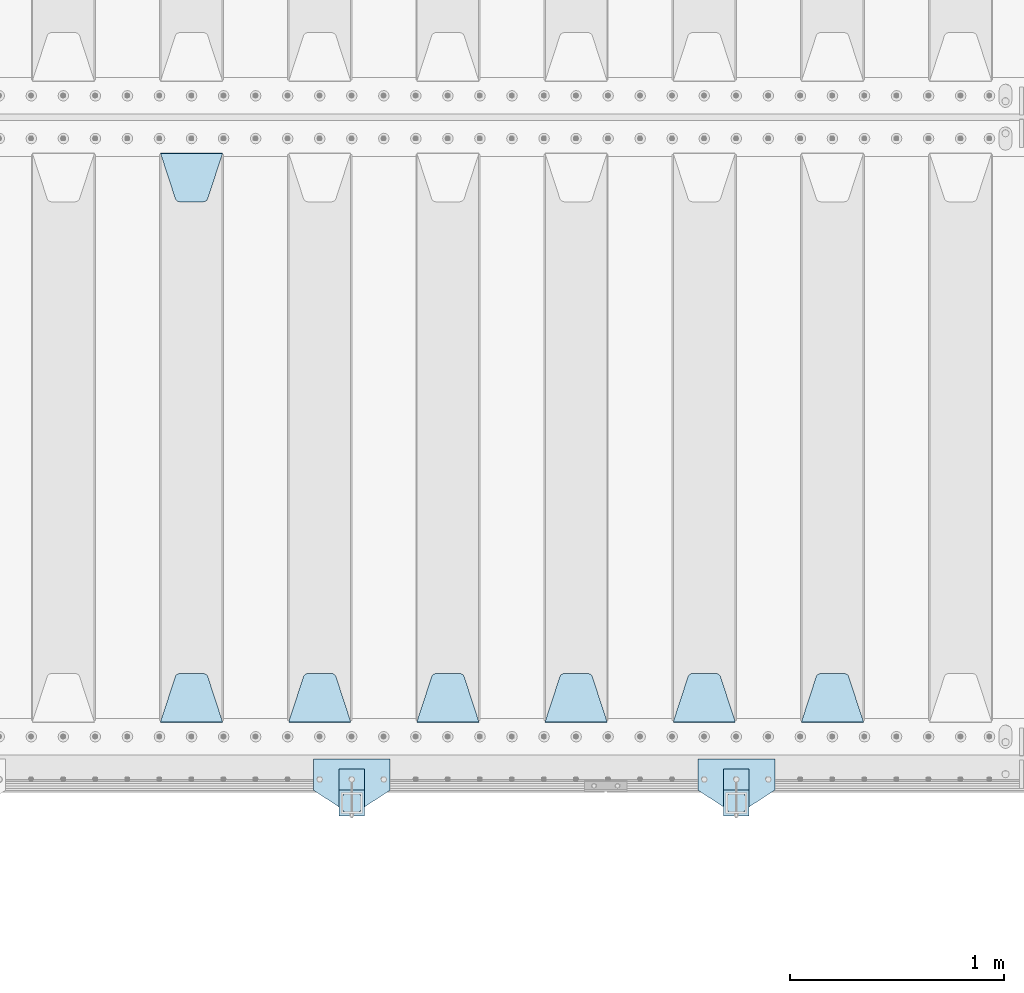
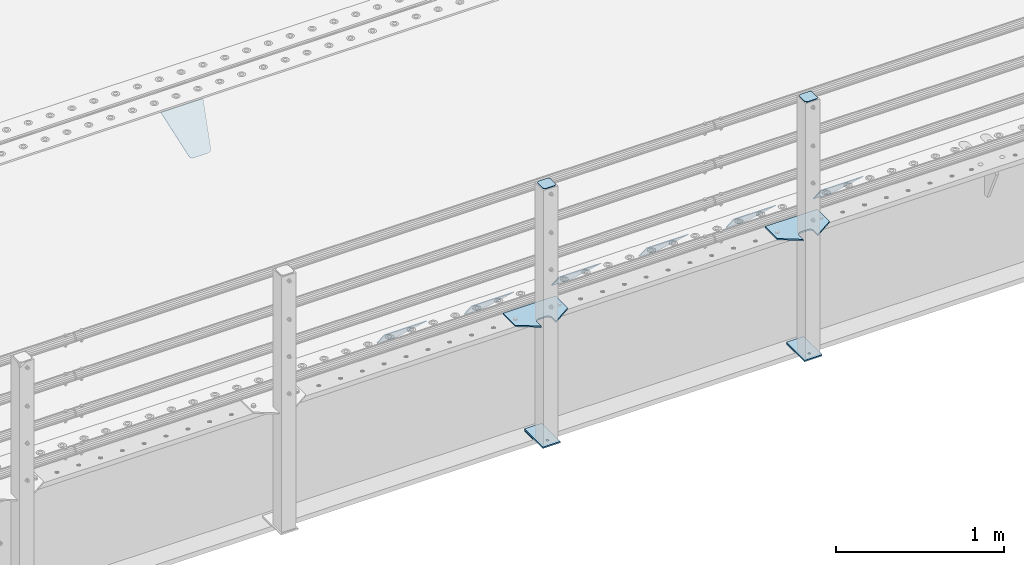
# One storey, part 216 of 270: 15 plates.
"""IFC2X3 building model written with IfcOpenShell, lengths in millimetres."""

from ifc_helpers import new_model, si_unit, frame, origin_with_axes, place, context, subcontext, project, spatial, faceted_brep, material, type_object, element, save


model = new_model("IFC2X3")

# Units and contexts
model_context = context("Model", 3, precision=1e-05, world=origin_with_axes())
body_context = subcontext(model_context, "Body", "Model", "MODEL_VIEW")
ifc_project = project(units=[si_unit("LENGTHUNIT", "METRE", prefix="MILLI"), si_unit("AREAUNIT", "SQUARE_METRE"), si_unit("VOLUMEUNIT", "CUBIC_METRE"), si_unit("MASSUNIT", "GRAM", prefix="KILO"), si_unit("TIMEUNIT", "SECOND"), si_unit("PLANEANGLEUNIT", "RADIAN"), si_unit("SOLIDANGLEUNIT", "STERADIAN"), si_unit("THERMODYNAMICTEMPERATUREUNIT", "DEGREE_CELSIUS"), si_unit("LUMINOUSINTENSITYUNIT", "LUMEN")], contexts=[model_context])

# Site, building, storey
site_placement = place(None, origin_with_axes())
site = spatial("IfcSite", under=ifc_project, at=site_placement, CompositionType="ELEMENT")
building_placement = place(site_placement, origin_with_axes())
building = spatial("IfcBuilding", under=site, at=building_placement, Name="Standard", CompositionType="ELEMENT")
storey_placement = place(building_placement, origin_with_axes())
storey = spatial("IfcBuildingStorey", under=building, at=storey_placement, Name="Undefined", CompositionType="ELEMENT", Elevation=0.0)

# Plates
ifc_material_1 = material(Name="STEEL/S355J2")
plate_type_1 = type_object("IfcPlateType", PredefinedType="NOTDEFINED")
plate_1_placement = place(storey_placement, frame((6130.0, -24005.0, 5.00000000004911), z_axis=(0.0, -1.0, 0.0), x_axis=(-1.0, 0.0, 0.0)))
element("IfcPlate", 1, at=plate_1_placement, inside=storey, type_object=plate_type_1, material=ifc_material_1, context=body_context, shape_type="Brep", body=[
    faceted_brep([(0.0, -5.0, 0.0), (2.31396552408114e-06, -5.0, 145.0), (2.31396552408114e-06, 5.0, 145.0), (0.0, 5.0, 0.0), (130.0, -5.0, 230.0), (130.0, 5.0, 230.0), (130.0, -5.0, 180.0), (130.0, 5.0, 180.0), (130.48036798992, -5.0, 175.122741949597), (130.48036798992, 5.0, 175.122741949597), (131.903011687216, -5.0, 170.432914190873), (131.903011687216, 5.0, 170.432914190873), (134.213259692435, -5.0, 166.11074417451), (134.213259692435, 5.0, 166.11074417451), (137.322330470335, -5.0, 162.322330470337), (137.322330470335, 5.0, 162.322330470337), (141.110744174512, -5.0, 159.213259692437), (141.110744174512, 5.0, 159.213259692437), (145.432914190871, -5.0, 156.903011687218), (145.432914190871, 5.0, 156.903011687218), (150.122741949595, -5.0, 155.48036798992), (150.122741949595, 5.0, 155.48036798992), (155.0, -5.0, 155.0), (155.0, 5.0, 155.0), (205.0, -5.0, 155.0), (205.0, 5.0, 155.0), (209.877258050405, -5.0, 155.48036798992), (209.877258050405, 5.0, 155.48036798992), (214.567085809129, -5.0, 156.903011687218), (214.567085809129, 5.0, 156.903011687218), (218.889255825488, -5.0, 159.213259692437), (218.889255825488, 5.0, 159.213259692437), (222.677669529665, -5.0, 162.322330470337), (222.677669529665, 5.0, 162.322330470337), (225.786740307565, -5.0, 166.11074417451), (225.786740307565, 5.0, 166.11074417451), (228.096988312784, -5.0, 170.432914190873), (228.096988312784, 5.0, 170.432914190873), (229.51963201008, -5.0, 175.122741949597), (229.51963201008, 5.0, 175.122741949597), (230.0, -5.0, 180.0), (230.0, 5.0, 180.0), (230.0, -5.0, 230.0), (230.0, 5.0, 230.0), (360.0, -5.0, 145.0), (360.0, 5.0, 145.0), (360.0, -5.0, -7.27595761418343e-12), (360.0, 5.0, -7.27595761418343e-12)], [[[0, 1, 2, 3]], [[1, 4, 5, 2]], [[4, 6, 7, 5]], [[6, 8, 9, 7]], [[8, 10, 11, 9]], [[10, 12, 13, 11]], [[12, 14, 15, 13]], [[14, 16, 17, 15]], [[16, 18, 19, 17]], [[18, 20, 21, 19]], [[20, 22, 23, 21]], [[22, 24, 25, 23]], [[24, 26, 27, 25]], [[26, 28, 29, 27]], [[28, 30, 31, 29]], [[30, 32, 33, 31]], [[32, 34, 35, 33]], [[34, 36, 37, 35]], [[36, 38, 39, 37]], [[38, 40, 41, 39]], [[40, 42, 43, 41]], [[42, 44, 45, 43]], [[44, 46, 47, 45]], [[46, 0, 3, 47]], [[5, 7, 9, 11, 13, 15, 17, 19, 21, 23, 25, 27, 29, 31, 33, 35, 37, 39, 41, 43, 45, 47, 3, 2]], [[46, 44, 42, 40, 38, 36, 34, 32, 30, 28, 26, 24, 22, 20, 18, 16, 14, 12, 10, 8, 6, 4, 1, 0]]]),
])
plate_2_placement = place(storey_placement, frame((4330.0, -24005.0, 5.00000000004911), z_axis=(0.0, -1.0, 0.0), x_axis=(-1.0, 0.0, 0.0)))
element("IfcPlate", 2, at=plate_2_placement, inside=storey, type_object=plate_type_1, material=ifc_material_1, context=body_context, shape_type="Brep", body=[
    faceted_brep([(0.0, -5.0, 0.0), (2.31396552408114e-06, -5.0, 145.0), (2.31396552408114e-06, 5.0, 145.0), (0.0, 5.0, 0.0), (130.0, -5.0, 230.0), (130.0, 5.0, 230.0), (130.0, -5.0, 180.0), (130.0, 5.0, 180.0), (130.48036798992, -5.0, 175.122741949597), (130.48036798992, 5.0, 175.122741949597), (131.903011687216, -5.0, 170.432914190873), (131.903011687216, 5.0, 170.432914190873), (134.213259692435, -5.0, 166.11074417451), (134.213259692435, 5.0, 166.11074417451), (137.322330470335, -5.0, 162.322330470337), (137.322330470335, 5.0, 162.322330470337), (141.110744174512, -5.0, 159.213259692437), (141.110744174512, 5.0, 159.213259692437), (145.432914190871, -5.0, 156.903011687218), (145.432914190871, 5.0, 156.903011687218), (150.122741949595, -5.0, 155.48036798992), (150.122741949595, 5.0, 155.48036798992), (155.0, -5.0, 155.0), (155.0, 5.0, 155.0), (205.0, -5.0, 155.0), (205.0, 5.0, 155.0), (209.877258050405, -5.0, 155.48036798992), (209.877258050405, 5.0, 155.48036798992), (214.567085809129, -5.0, 156.903011687218), (214.567085809129, 5.0, 156.903011687218), (218.889255825488, -5.0, 159.213259692437), (218.889255825488, 5.0, 159.213259692437), (222.677669529665, -5.0, 162.322330470337), (222.677669529665, 5.0, 162.322330470337), (225.786740307565, -5.0, 166.11074417451), (225.786740307565, 5.0, 166.11074417451), (228.096988312784, -5.0, 170.432914190873), (228.096988312784, 5.0, 170.432914190873), (229.51963201008, -5.0, 175.122741949597), (229.51963201008, 5.0, 175.122741949597), (230.0, -5.0, 180.0), (230.0, 5.0, 180.0), (230.0, -5.0, 230.0), (230.0, 5.0, 230.0), (360.0, -5.0, 145.0), (360.0, 5.0, 145.0), (360.0, -5.0, -7.27595761418343e-12), (360.0, 5.0, -7.27595761418343e-12)], [[[0, 1, 2, 3]], [[1, 4, 5, 2]], [[4, 6, 7, 5]], [[6, 8, 9, 7]], [[8, 10, 11, 9]], [[10, 12, 13, 11]], [[12, 14, 15, 13]], [[14, 16, 17, 15]], [[16, 18, 19, 17]], [[18, 20, 21, 19]], [[20, 22, 23, 21]], [[22, 24, 25, 23]], [[24, 26, 27, 25]], [[26, 28, 29, 27]], [[28, 30, 31, 29]], [[30, 32, 33, 31]], [[32, 34, 35, 33]], [[34, 36, 37, 35]], [[36, 38, 39, 37]], [[38, 40, 41, 39]], [[40, 42, 43, 41]], [[42, 44, 45, 43]], [[44, 46, 47, 45]], [[46, 0, 3, 47]], [[5, 7, 9, 11, 13, 15, 17, 19, 21, 23, 25, 27, 29, 31, 33, 35, 37, 39, 41, 43, 45, 47, 3, 2]], [[46, 44, 42, 40, 38, 36, 34, 32, 30, 28, 26, 24, 22, 20, 18, 16, 14, 12, 10, 8, 6, 4, 1, 0]]]),
])
plate_type_2 = type_object("IfcPlateType", PredefinedType="NOTDEFINED")
for number, where, z_axis, x_axis in (
    (3, (6009.99999999986, -24050.0000000002, -850.000000000002), (0.0, -1.0, 0.0), (-1.0, 0.0, 0.0)),
    (4, (4209.99999999986, -24050.0000000002, -850.000000000002), (0.0, -1.0, 0.0), (-1.0, 0.0, 0.0)),
):
    element("IfcPlate", number, at=place(storey_placement, frame(where, z_axis=z_axis, x_axis=x_axis)), inside=storey, type_object=plate_type_2, material=ifc_material_1, context=body_context, shape_type="Brep", body=[
        faceted_brep([(53.6360389691836, -5.0, 176.363961030471), (53.6360389691836, 5.0, 176.363961030471), (59.9999999998618, 5.0, 178.999999999793), (59.9999999998618, -5.0, 178.999999999793), (66.3639610305399, 5.0, 176.363961030471), (66.3639610305399, -5.0, 176.363961030471), (68.9999999998618, 5.0, 169.999999999793), (68.9999999998618, -5.0, 169.999999999793), (66.3639610305399, 5.0, 163.636038969114), (66.3639610305399, -5.0, 163.636038969114), (59.9999999998618, 5.0, 160.999999999793), (59.9999999998618, -5.0, 160.999999999793), (53.6360389691836, 5.0, 163.636038969114), (53.6360389691836, -5.0, 163.636038969114), (50.9999999998618, 5.0, 169.999999999793), (50.9999999998618, -5.0, 169.999999999793), (120.0, -5.0, 0.0), (120.0, -5.0, 220.0), (0.0, -5.0, 220.0), (0.0, -5.0, 0.0), (0.0, 5.0, 0.0), (120.0, 5.0, 0.0), (120.0, 5.0, 220.0), (0.0, 5.0, 220.0)], [[[0, 1, 2, 3]], [[3, 2, 4, 5]], [[5, 4, 6, 7]], [[7, 6, 8, 9]], [[9, 8, 10, 11]], [[11, 10, 12, 13]], [[13, 12, 14, 15]], [[15, 14, 1, 0]], [[16, 17, 18, 19], [11, 13, 15, 0, 3, 5, 7, 9]], [[16, 19, 20, 21]], [[17, 16, 21, 22]], [[18, 17, 22, 23]], [[19, 18, 23, 20]], [[22, 21, 20, 23], [2, 1, 14, 12, 10, 8, 6, 4]]]),
    ])
plate_type_3 = type_object("IfcPlateType", PredefinedType="NOTDEFINED")
plate_3_placement = place(storey_placement, frame((5905.99999999987, -24166.0000000002, 1012.50000000001), z_axis=(0.0, -1.0, 0.0), x_axis=(1.0, 0.0, 0.0)))
element("IfcPlate", 5, at=plate_3_placement, inside=storey, type_object=plate_type_3, material=ifc_material_1, context=body_context, shape_type="Brep", body=[
    faceted_brep([(0.0, -2.5, 19.0), (0.0, -2.5, 69.0), (0.0, 2.5, 69.0), (0.0, 2.5, 19.0), (0.476369668544066, -2.5, 73.2278977451697), (0.476369668544066, 2.5, 73.2278977451697), (1.88159150985302, -2.5, 77.2437910432327), (1.88159150985302, 2.5, 77.2437910432327), (4.14520183310742, -2.5, 80.8463062353167), (4.14520183310742, 2.5, 80.8463062353167), (7.15369376468516, -2.5, 83.8547981668926), (7.15369376468516, 2.5, 83.8547981668926), (10.7562089567655, -2.5, 86.1184084901452), (10.7562089567655, 2.5, 86.1184084901452), (14.7721022548285, -2.5, 87.5236303314541), (14.7721022548285, 2.5, 87.5236303314541), (19.0, -2.5, 88.0), (19.0, 2.5, 88.0), (69.0, -2.5, 88.0), (69.0, 2.5, 88.0), (73.2278977451715, -2.5, 87.5236303314541), (73.2278977451715, 2.5, 87.5236303314541), (77.2437910432345, -2.5, 86.1184084901452), (77.2437910432345, 2.5, 86.1184084901452), (80.8463062353148, -2.5, 83.8547981668926), (80.8463062353148, 2.5, 83.8547981668926), (83.8547981668926, -2.5, 80.8463062353167), (83.8547981668926, 2.5, 80.8463062353167), (86.118408490147, -2.5, 77.2437910432345), (86.118408490147, 2.5, 77.2437910432345), (87.5236303314559, -2.5, 73.2278977451697), (87.5236303314559, 2.5, 73.2278977451697), (88.0, -2.5, 69.0), (88.0, 2.5, 69.0), (88.0, -2.5, 19.0), (88.0, 2.5, 19.0), (87.5236303314559, -2.5, 14.7721022548303), (87.5236303314559, 2.5, 14.7721022548303), (86.118408490147, -2.5, 10.7562089567673), (86.118408490147, 2.5, 10.7562089567673), (83.8547981668926, -2.5, 7.15369376468334), (83.8547981668926, 2.5, 7.15369376468334), (80.8463062353148, -2.5, 4.14520183310742), (80.8463062353148, 2.5, 4.14520183310742), (77.2437910432345, -2.5, 1.88159150985484), (77.2437910432345, 2.5, 1.88159150985484), (73.2278977451715, -2.5, 0.476369668545885), (73.2278977451715, 2.5, 0.476369668545885), (69.0, -2.5, 0.0), (69.0, 2.5, 0.0), (19.0, -2.5, 0.0), (19.0, 2.5, 0.0), (14.7721022548285, -2.5, 0.476369668545885), (14.7721022548285, 2.5, 0.476369668545885), (10.7562089567655, -2.5, 1.88159150985484), (10.7562089567655, 2.5, 1.88159150985484), (7.15369376468516, -2.5, 4.14520183310742), (7.15369376468516, 2.5, 4.14520183310742), (4.14520183310742, -2.5, 7.15369376468334), (4.14520183310742, 2.5, 7.15369376468334), (1.88159150985302, -2.5, 10.7562089567673), (1.88159150985302, 2.5, 10.7562089567673), (0.476369668544066, -2.5, 14.7721022548303), (0.476369668544066, 2.5, 14.7721022548303)], [[[0, 1, 2, 3]], [[1, 4, 5, 2]], [[4, 6, 7, 5]], [[6, 8, 9, 7]], [[8, 10, 11, 9]], [[10, 12, 13, 11]], [[12, 14, 15, 13]], [[14, 16, 17, 15]], [[16, 18, 19, 17]], [[18, 20, 21, 19]], [[20, 22, 23, 21]], [[22, 24, 25, 23]], [[24, 26, 27, 25]], [[26, 28, 29, 27]], [[28, 30, 31, 29]], [[30, 32, 33, 31]], [[32, 34, 35, 33]], [[34, 36, 37, 35]], [[36, 38, 39, 37]], [[38, 40, 41, 39]], [[40, 42, 43, 41]], [[42, 44, 45, 43]], [[44, 46, 47, 45]], [[46, 48, 49, 47]], [[48, 50, 51, 49]], [[50, 52, 53, 51]], [[52, 54, 55, 53]], [[54, 56, 57, 55]], [[56, 58, 59, 57]], [[58, 60, 61, 59]], [[60, 62, 63, 61]], [[62, 0, 3, 63]], [[5, 7, 9, 11, 13, 15, 17, 19, 21, 23, 25, 27, 29, 31, 33, 35, 37, 39, 41, 43, 45, 47, 49, 51, 53, 55, 57, 59, 61, 63, 3, 2]], [[62, 60, 58, 56, 54, 52, 50, 48, 46, 44, 42, 40, 38, 36, 34, 32, 30, 28, 26, 24, 22, 20, 18, 16, 14, 12, 10, 8, 6, 4, 1, 0]]]),
])
plate_4_placement = place(storey_placement, frame((4105.99999999987, -24166.0000000002, 1012.50000000001), z_axis=(0.0, -1.0, 0.0), x_axis=(1.0, 0.0, 0.0)))
element("IfcPlate", 6, at=plate_4_placement, inside=storey, type_object=plate_type_3, material=ifc_material_1, context=body_context, shape_type="Brep", body=[
    faceted_brep([(0.0, -2.5, 19.0), (0.0, -2.5, 69.0), (0.0, 2.5, 69.0), (0.0, 2.5, 19.0), (0.476369668544066, -2.5, 73.2278977451697), (0.476369668544066, 2.5, 73.2278977451697), (1.88159150985302, -2.5, 77.2437910432327), (1.88159150985302, 2.5, 77.2437910432327), (4.14520183310742, -2.5, 80.8463062353167), (4.14520183310742, 2.5, 80.8463062353167), (7.15369376468516, -2.5, 83.8547981668926), (7.15369376468516, 2.5, 83.8547981668926), (10.7562089567655, -2.5, 86.1184084901452), (10.7562089567655, 2.5, 86.1184084901452), (14.7721022548285, -2.5, 87.5236303314541), (14.7721022548285, 2.5, 87.5236303314541), (19.0, -2.5, 88.0), (19.0, 2.5, 88.0), (69.0, -2.5, 88.0), (69.0, 2.5, 88.0), (73.2278977451715, -2.5, 87.5236303314541), (73.2278977451715, 2.5, 87.5236303314541), (77.2437910432345, -2.5, 86.1184084901452), (77.2437910432345, 2.5, 86.1184084901452), (80.8463062353148, -2.5, 83.8547981668926), (80.8463062353148, 2.5, 83.8547981668926), (83.8547981668926, -2.5, 80.8463062353167), (83.8547981668926, 2.5, 80.8463062353167), (86.118408490147, -2.5, 77.2437910432345), (86.118408490147, 2.5, 77.2437910432345), (87.5236303314559, -2.5, 73.2278977451697), (87.5236303314559, 2.5, 73.2278977451697), (88.0, -2.5, 69.0), (88.0, 2.5, 69.0), (88.0, -2.5, 19.0), (88.0, 2.5, 19.0), (87.5236303314559, -2.5, 14.7721022548303), (87.5236303314559, 2.5, 14.7721022548303), (86.118408490147, -2.5, 10.7562089567673), (86.118408490147, 2.5, 10.7562089567673), (83.8547981668926, -2.5, 7.15369376468334), (83.8547981668926, 2.5, 7.15369376468334), (80.8463062353148, -2.5, 4.14520183310742), (80.8463062353148, 2.5, 4.14520183310742), (77.2437910432345, -2.5, 1.88159150985484), (77.2437910432345, 2.5, 1.88159150985484), (73.2278977451715, -2.5, 0.476369668545885), (73.2278977451715, 2.5, 0.476369668545885), (69.0, -2.5, 0.0), (69.0, 2.5, 0.0), (19.0, -2.5, 0.0), (19.0, 2.5, 0.0), (14.7721022548285, -2.5, 0.476369668545885), (14.7721022548285, 2.5, 0.476369668545885), (10.7562089567655, -2.5, 1.88159150985484), (10.7562089567655, 2.5, 1.88159150985484), (7.15369376468516, -2.5, 4.14520183310742), (7.15369376468516, 2.5, 4.14520183310742), (4.14520183310742, -2.5, 7.15369376468334), (4.14520183310742, 2.5, 7.15369376468334), (1.88159150985302, -2.5, 10.7562089567673), (1.88159150985302, 2.5, 10.7562089567673), (0.476369668544066, -2.5, 14.7721022548303), (0.476369668544066, 2.5, 14.7721022548303)], [[[0, 1, 2, 3]], [[1, 4, 5, 2]], [[4, 6, 7, 5]], [[6, 8, 9, 7]], [[8, 10, 11, 9]], [[10, 12, 13, 11]], [[12, 14, 15, 13]], [[14, 16, 17, 15]], [[16, 18, 19, 17]], [[18, 20, 21, 19]], [[20, 22, 23, 21]], [[22, 24, 25, 23]], [[24, 26, 27, 25]], [[26, 28, 29, 27]], [[28, 30, 31, 29]], [[30, 32, 33, 31]], [[32, 34, 35, 33]], [[34, 36, 37, 35]], [[36, 38, 39, 37]], [[38, 40, 41, 39]], [[40, 42, 43, 41]], [[42, 44, 45, 43]], [[44, 46, 47, 45]], [[46, 48, 49, 47]], [[48, 50, 51, 49]], [[50, 52, 53, 51]], [[52, 54, 55, 53]], [[54, 56, 57, 55]], [[56, 58, 59, 57]], [[58, 60, 61, 59]], [[60, 62, 63, 61]], [[62, 0, 3, 63]], [[5, 7, 9, 11, 13, 15, 17, 19, 21, 23, 25, 27, 29, 31, 33, 35, 37, 39, 41, 43, 45, 47, 49, 51, 53, 55, 57, 59, 61, 63, 3, 2]], [[62, 60, 58, 56, 54, 52, 50, 48, 46, 44, 42, 40, 38, 36, 34, 32, 30, 28, 26, 24, 22, 20, 18, 16, 14, 12, 10, 8, 6, 4, 1, 0]]]),
])
plate_type_4 = type_object("IfcPlateType", PredefinedType="NOTDEFINED")
for number, where, z_axis, x_axis in (
    (7, (6009.99999999986, -24050.0000000002, -857.500000000002), (0.0, -1.0, 0.0), (-1.0, 0.0, 0.0)),
    (8, (4209.99999999986, -24050.0000000002, -857.500000000002), (0.0, -1.0, 0.0), (-1.0, 0.0, 0.0)),
):
    element("IfcPlate", number, at=place(storey_placement, frame(where, z_axis=z_axis, x_axis=x_axis)), inside=storey, type_object=plate_type_4, material=ifc_material_1, context=body_context, shape_type="Brep", body=[
        faceted_brep([(0.0, -2.5, 0.0), (0.0, -2.5, 100.0), (0.0, 2.5, 100.0), (0.0, 2.5, 0.0), (120.0, -2.5, 100.0), (120.0, 2.5, 100.0), (120.0, -2.5, 0.0), (120.0, 2.5, 0.0)], [[[0, 1, 2, 3]], [[1, 4, 5, 2]], [[4, 6, 7, 5]], [[6, 0, 3, 7]], [[5, 7, 3, 2]], [[6, 4, 1, 0]]]),
    ])
ifc_material_2 = material(Name="STEEL/S355N")
plate_type_5 = type_object("IfcPlateType", PredefinedType="NOTDEFINED")
plate_5_placement = place(storey_placement, frame((6545.0, -23831.767766953, -1.76776695296758), z_axis=(0.0, 0.707106781186547, -0.707106781186548), x_axis=(-1.0, 0.0, 0.0)))
element("IfcPlate", 9, at=plate_5_placement, inside=storey, type_object=plate_type_5, material=ifc_material_2, context=body_context, shape_type="Brep", body=[
    faceted_brep([(0.0, -2.5, 0.0), (69.345504679477, -2.5, 300.171731424831), (69.345504679477, 2.5, 300.171731424831), (0.0, 2.5, 0.0), (70.9274061199576, -2.5, 304.8974424154), (70.9274061199576, 2.5, 304.8974424154), (73.3818627772307, -2.49999999999818, 309.234538108527), (73.3818627772307, 2.50000000000182, 309.234538108527), (76.6187032999551, -2.5, 313.023683126103), (76.6187032999551, 2.5, 313.023683126103), (80.5190132704993, -2.5, 316.125672595372), (80.5190132704993, 2.50000000000182, 316.125672595372), (84.9395038596849, -2.49999999999818, 318.426546230476), (84.9395038596849, 2.5, 318.426546230476), (89.7177759439219, -2.49999999999818, 319.841774983275), (89.7177759439219, 2.50000000000182, 319.841774983275), (94.678286292652, -2.5, 320.319366455078), (94.678286292652, 2.5, 320.319366455078), (195.321713707348, -2.5, 320.319366455078), (195.321713707348, 2.5, 320.319366455078), (200.282224056078, -2.49999999999818, 319.841774983275), (200.282224056078, 2.50000000000182, 319.841774983275), (205.060496140315, -2.5, 318.426546230476), (205.060496140315, 2.5, 318.426546230476), (209.480986729501, -2.5, 316.12567259537), (209.480986729501, 2.50000000000182, 316.12567259537), (213.381296700045, -2.5, 313.023683126103), (213.381296700045, 2.5, 313.023683126103), (216.618137222769, -2.49999999999818, 309.234538108525), (216.618137222769, 2.50000000000182, 309.234538108527), (219.072593880042, -2.49999999999818, 304.897442415398), (219.072593880042, 2.50000000000182, 304.897442415397), (220.654495320523, -2.5, 300.171731424831), (220.654495320523, 2.5, 300.171731424831), (290.0, -2.49999999999818, 0.0), (290.0, 2.5, 0.0)], [[[0, 1, 2, 3]], [[1, 4, 5, 2]], [[4, 6, 7, 5]], [[6, 8, 9, 7]], [[8, 10, 11, 9]], [[10, 12, 13, 11]], [[12, 14, 15, 13]], [[14, 16, 17, 15]], [[16, 18, 19, 17]], [[18, 20, 21, 19]], [[20, 22, 23, 21]], [[22, 24, 25, 23]], [[24, 26, 27, 25]], [[26, 28, 29, 27]], [[28, 30, 31, 29]], [[30, 32, 33, 31]], [[32, 34, 35, 33]], [[34, 0, 3, 35]], [[5, 7, 9, 11, 13, 15, 17, 19, 21, 23, 25, 27, 29, 31, 33, 35, 3, 2]], [[34, 32, 30, 28, 26, 24, 22, 20, 18, 16, 14, 12, 10, 8, 6, 4, 1, 0]]]),
])
plate_6_placement = place(storey_placement, frame((5945.0, -23831.767766953, -1.76776695296758), z_axis=(0.0, 0.707106781186547, -0.707106781186548), x_axis=(-1.0, 0.0, 0.0)))
element("IfcPlate", 10, at=plate_6_placement, inside=storey, type_object=plate_type_5, material=ifc_material_2, context=body_context, shape_type="Brep", body=[
    faceted_brep([(0.0, -2.5, 0.0), (69.345504679477, -2.5, 300.171731424831), (69.345504679477, 2.5, 300.171731424831), (0.0, 2.5, 0.0), (70.9274061199576, -2.5, 304.8974424154), (70.9274061199576, 2.5, 304.8974424154), (73.3818627772307, -2.49999999999818, 309.234538108527), (73.3818627772307, 2.50000000000182, 309.234538108527), (76.6187032999551, -2.5, 313.023683126103), (76.6187032999551, 2.5, 313.023683126103), (80.5190132704993, -2.5, 316.125672595372), (80.5190132704993, 2.50000000000182, 316.125672595372), (84.9395038596849, -2.49999999999818, 318.426546230476), (84.9395038596849, 2.5, 318.426546230476), (89.7177759439219, -2.49999999999818, 319.841774983275), (89.7177759439219, 2.50000000000182, 319.841774983275), (94.678286292652, -2.5, 320.319366455078), (94.678286292652, 2.5, 320.319366455078), (195.321713707348, -2.5, 320.319366455078), (195.321713707348, 2.5, 320.319366455078), (200.282224056078, -2.49999999999818, 319.841774983275), (200.282224056078, 2.50000000000182, 319.841774983275), (205.060496140315, -2.5, 318.426546230476), (205.060496140315, 2.5, 318.426546230476), (209.480986729501, -2.5, 316.12567259537), (209.480986729501, 2.50000000000182, 316.12567259537), (213.381296700045, -2.5, 313.023683126103), (213.381296700045, 2.5, 313.023683126103), (216.618137222769, -2.49999999999818, 309.234538108525), (216.618137222769, 2.50000000000182, 309.234538108527), (219.072593880042, -2.49999999999818, 304.897442415398), (219.072593880042, 2.50000000000182, 304.897442415397), (220.654495320523, -2.5, 300.171731424831), (220.654495320523, 2.5, 300.171731424831), (290.0, -2.49999999999818, 0.0), (290.0, 2.5, 0.0)], [[[0, 1, 2, 3]], [[1, 4, 5, 2]], [[4, 6, 7, 5]], [[6, 8, 9, 7]], [[8, 10, 11, 9]], [[10, 12, 13, 11]], [[12, 14, 15, 13]], [[14, 16, 17, 15]], [[16, 18, 19, 17]], [[18, 20, 21, 19]], [[20, 22, 23, 21]], [[22, 24, 25, 23]], [[24, 26, 27, 25]], [[26, 28, 29, 27]], [[28, 30, 31, 29]], [[30, 32, 33, 31]], [[32, 34, 35, 33]], [[34, 0, 3, 35]], [[5, 7, 9, 11, 13, 15, 17, 19, 21, 23, 25, 27, 29, 31, 33, 35, 3, 2]], [[34, 32, 30, 28, 26, 24, 22, 20, 18, 16, 14, 12, 10, 8, 6, 4, 1, 0]]]),
])
plate_7_placement = place(storey_placement, frame((5345.0, -23831.767766953, -1.76776695296758), z_axis=(0.0, 0.707106781186547, -0.707106781186548), x_axis=(-1.0, 0.0, 0.0)))
element("IfcPlate", 11, at=plate_7_placement, inside=storey, type_object=plate_type_5, material=ifc_material_2, context=body_context, shape_type="Brep", body=[
    faceted_brep([(0.0, -2.5, 0.0), (69.345504679477, -2.5, 300.171731424831), (69.345504679477, 2.5, 300.171731424831), (0.0, 2.5, 0.0), (70.9274061199576, -2.5, 304.8974424154), (70.9274061199576, 2.5, 304.8974424154), (73.3818627772307, -2.49999999999818, 309.234538108527), (73.3818627772307, 2.50000000000182, 309.234538108527), (76.6187032999551, -2.5, 313.023683126103), (76.6187032999551, 2.5, 313.023683126103), (80.5190132704993, -2.5, 316.125672595372), (80.5190132704993, 2.50000000000182, 316.125672595372), (84.9395038596849, -2.49999999999818, 318.426546230476), (84.9395038596849, 2.5, 318.426546230476), (89.7177759439219, -2.49999999999818, 319.841774983275), (89.7177759439219, 2.50000000000182, 319.841774983275), (94.678286292652, -2.5, 320.319366455078), (94.678286292652, 2.5, 320.319366455078), (195.321713707348, -2.5, 320.319366455078), (195.321713707348, 2.5, 320.319366455078), (200.282224056078, -2.49999999999818, 319.841774983275), (200.282224056078, 2.50000000000182, 319.841774983275), (205.060496140315, -2.5, 318.426546230476), (205.060496140315, 2.5, 318.426546230476), (209.480986729501, -2.5, 316.12567259537), (209.480986729501, 2.50000000000182, 316.12567259537), (213.381296700045, -2.5, 313.023683126103), (213.381296700045, 2.5, 313.023683126103), (216.618137222769, -2.49999999999818, 309.234538108525), (216.618137222769, 2.50000000000182, 309.234538108527), (219.072593880042, -2.49999999999818, 304.897442415398), (219.072593880042, 2.50000000000182, 304.897442415397), (220.654495320523, -2.5, 300.171731424831), (220.654495320523, 2.5, 300.171731424831), (290.0, -2.49999999999818, 0.0), (290.0, 2.5, 0.0)], [[[0, 1, 2, 3]], [[1, 4, 5, 2]], [[4, 6, 7, 5]], [[6, 8, 9, 7]], [[8, 10, 11, 9]], [[10, 12, 13, 11]], [[12, 14, 15, 13]], [[14, 16, 17, 15]], [[16, 18, 19, 17]], [[18, 20, 21, 19]], [[20, 22, 23, 21]], [[22, 24, 25, 23]], [[24, 26, 27, 25]], [[26, 28, 29, 27]], [[28, 30, 31, 29]], [[30, 32, 33, 31]], [[32, 34, 35, 33]], [[34, 0, 3, 35]], [[5, 7, 9, 11, 13, 15, 17, 19, 21, 23, 25, 27, 29, 31, 33, 35, 3, 2]], [[34, 32, 30, 28, 26, 24, 22, 20, 18, 16, 14, 12, 10, 8, 6, 4, 1, 0]]]),
])
plate_8_placement = place(storey_placement, frame((4745.0, -23831.767766953, -1.76776695296758), z_axis=(0.0, 0.707106781186547, -0.707106781186548), x_axis=(-1.0, 0.0, 0.0)))
element("IfcPlate", 12, at=plate_8_placement, inside=storey, type_object=plate_type_5, material=ifc_material_2, context=body_context, shape_type="Brep", body=[
    faceted_brep([(0.0, -2.5, 0.0), (69.345504679477, -2.5, 300.171731424831), (69.345504679477, 2.5, 300.171731424831), (0.0, 2.5, 0.0), (70.9274061199576, -2.5, 304.8974424154), (70.9274061199576, 2.5, 304.8974424154), (73.3818627772307, -2.49999999999818, 309.234538108527), (73.3818627772307, 2.50000000000182, 309.234538108527), (76.6187032999551, -2.5, 313.023683126103), (76.6187032999551, 2.5, 313.023683126103), (80.5190132704993, -2.5, 316.125672595372), (80.5190132704993, 2.50000000000182, 316.125672595372), (84.9395038596849, -2.49999999999818, 318.426546230476), (84.9395038596849, 2.5, 318.426546230476), (89.7177759439219, -2.49999999999818, 319.841774983275), (89.7177759439219, 2.50000000000182, 319.841774983275), (94.678286292652, -2.5, 320.319366455078), (94.678286292652, 2.5, 320.319366455078), (195.321713707348, -2.5, 320.319366455078), (195.321713707348, 2.5, 320.319366455078), (200.282224056078, -2.49999999999818, 319.841774983275), (200.282224056078, 2.50000000000182, 319.841774983275), (205.060496140315, -2.5, 318.426546230476), (205.060496140315, 2.5, 318.426546230476), (209.480986729501, -2.5, 316.12567259537), (209.480986729501, 2.50000000000182, 316.12567259537), (213.381296700045, -2.5, 313.023683126103), (213.381296700045, 2.5, 313.023683126103), (216.618137222769, -2.49999999999818, 309.234538108525), (216.618137222769, 2.50000000000182, 309.234538108527), (219.072593880042, -2.49999999999818, 304.897442415398), (219.072593880042, 2.50000000000182, 304.897442415397), (220.654495320523, -2.5, 300.171731424831), (220.654495320523, 2.5, 300.171731424831), (290.0, -2.49999999999818, 0.0), (290.0, 2.5, 0.0)], [[[0, 1, 2, 3]], [[1, 4, 5, 2]], [[4, 6, 7, 5]], [[6, 8, 9, 7]], [[8, 10, 11, 9]], [[10, 12, 13, 11]], [[12, 14, 15, 13]], [[14, 16, 17, 15]], [[16, 18, 19, 17]], [[18, 20, 21, 19]], [[20, 22, 23, 21]], [[22, 24, 25, 23]], [[24, 26, 27, 25]], [[26, 28, 29, 27]], [[28, 30, 31, 29]], [[30, 32, 33, 31]], [[32, 34, 35, 33]], [[34, 0, 3, 35]], [[5, 7, 9, 11, 13, 15, 17, 19, 21, 23, 25, 27, 29, 31, 33, 35, 3, 2]], [[34, 32, 30, 28, 26, 24, 22, 20, 18, 16, 14, 12, 10, 8, 6, 4, 1, 0]]]),
])
plate_9_placement = place(storey_placement, frame((4145.0, -23831.767766953, -1.76776695296758), z_axis=(0.0, 0.707106781186547, -0.707106781186548), x_axis=(-1.0, 0.0, 0.0)))
element("IfcPlate", 13, at=plate_9_placement, inside=storey, type_object=plate_type_5, material=ifc_material_2, context=body_context, shape_type="Brep", body=[
    faceted_brep([(0.0, -2.5, 0.0), (69.345504679477, -2.5, 300.171731424831), (69.345504679477, 2.5, 300.171731424831), (0.0, 2.5, 0.0), (70.9274061199576, -2.5, 304.8974424154), (70.9274061199576, 2.5, 304.8974424154), (73.3818627772307, -2.49999999999818, 309.234538108527), (73.3818627772307, 2.50000000000182, 309.234538108527), (76.6187032999551, -2.5, 313.023683126103), (76.6187032999551, 2.5, 313.023683126103), (80.5190132704993, -2.5, 316.125672595372), (80.5190132704993, 2.50000000000182, 316.125672595372), (84.9395038596849, -2.49999999999818, 318.426546230476), (84.9395038596849, 2.5, 318.426546230476), (89.7177759439219, -2.49999999999818, 319.841774983275), (89.7177759439219, 2.50000000000182, 319.841774983275), (94.678286292652, -2.5, 320.319366455078), (94.678286292652, 2.5, 320.319366455078), (195.321713707348, -2.5, 320.319366455078), (195.321713707348, 2.5, 320.319366455078), (200.282224056078, -2.49999999999818, 319.841774983275), (200.282224056078, 2.50000000000182, 319.841774983275), (205.060496140315, -2.5, 318.426546230476), (205.060496140315, 2.5, 318.426546230476), (209.480986729501, -2.5, 316.12567259537), (209.480986729501, 2.50000000000182, 316.12567259537), (213.381296700045, -2.5, 313.023683126103), (213.381296700045, 2.5, 313.023683126103), (216.618137222769, -2.49999999999818, 309.234538108525), (216.618137222769, 2.50000000000182, 309.234538108527), (219.072593880042, -2.49999999999818, 304.897442415398), (219.072593880042, 2.50000000000182, 304.897442415397), (220.654495320523, -2.5, 300.171731424831), (220.654495320523, 2.5, 300.171731424831), (290.0, -2.49999999999818, 0.0), (290.0, 2.5, 0.0)], [[[0, 1, 2, 3]], [[1, 4, 5, 2]], [[4, 6, 7, 5]], [[6, 8, 9, 7]], [[8, 10, 11, 9]], [[10, 12, 13, 11]], [[12, 14, 15, 13]], [[14, 16, 17, 15]], [[16, 18, 19, 17]], [[18, 20, 21, 19]], [[20, 22, 23, 21]], [[22, 24, 25, 23]], [[24, 26, 27, 25]], [[26, 28, 29, 27]], [[28, 30, 31, 29]], [[30, 32, 33, 31]], [[32, 34, 35, 33]], [[34, 0, 3, 35]], [[5, 7, 9, 11, 13, 15, 17, 19, 21, 23, 25, 27, 29, 31, 33, 35, 3, 2]], [[34, 32, 30, 28, 26, 24, 22, 20, 18, 16, 14, 12, 10, 8, 6, 4, 1, 0]]]),
])
plate_10_placement = place(storey_placement, frame((3255.0, -21168.232233044, -1.76776695296576), z_axis=(0.0, -0.707106781186548, -0.707106781186547), x_axis=(1.0, 0.0, 0.0)))
element("IfcPlate", 14, at=plate_10_placement, inside=storey, type_object=plate_type_5, material=ifc_material_2, context=body_context, shape_type="Brep", body=[
    faceted_brep([(0.0, -2.5, 0.0), (69.345504679477, -2.5, 300.171731424831), (69.345504679477, 2.5, 300.171731424831), (0.0, 2.5, 0.0), (70.9274061199576, -2.5, 304.8974424154), (70.9274061199576, 2.5, 304.8974424154), (73.3818627772307, -2.49999999999818, 309.234538108527), (73.3818627772307, 2.50000000000182, 309.234538108527), (76.6187032999551, -2.5, 313.023683126103), (76.6187032999551, 2.5, 313.023683126103), (80.5190132704993, -2.5, 316.125672595372), (80.5190132704993, 2.50000000000182, 316.125672595372), (84.9395038596849, -2.49999999999818, 318.426546230476), (84.9395038596849, 2.5, 318.426546230476), (89.7177759439219, -2.49999999999818, 319.841774983275), (89.7177759439219, 2.50000000000182, 319.841774983275), (94.678286292652, -2.5, 320.319366455078), (94.678286292652, 2.5, 320.319366455078), (195.321713707348, -2.5, 320.319366455078), (195.321713707348, 2.5, 320.319366455078), (200.282224056078, -2.49999999999818, 319.841774983275), (200.282224056078, 2.50000000000182, 319.841774983275), (205.060496140315, -2.5, 318.426546230476), (205.060496140315, 2.5, 318.426546230476), (209.480986729501, -2.5, 316.12567259537), (209.480986729501, 2.50000000000182, 316.12567259537), (213.381296700045, -2.5, 313.023683126103), (213.381296700045, 2.5, 313.023683126103), (216.618137222769, -2.49999999999818, 309.234538108525), (216.618137222769, 2.50000000000182, 309.234538108527), (219.072593880042, -2.49999999999818, 304.897442415398), (219.072593880042, 2.50000000000182, 304.897442415397), (220.654495320523, -2.5, 300.171731424831), (220.654495320523, 2.5, 300.171731424831), (290.0, -2.49999999999818, 0.0), (290.0, 2.5, 0.0)], [[[0, 1, 2, 3]], [[1, 4, 5, 2]], [[4, 6, 7, 5]], [[6, 8, 9, 7]], [[8, 10, 11, 9]], [[10, 12, 13, 11]], [[12, 14, 15, 13]], [[14, 16, 17, 15]], [[16, 18, 19, 17]], [[18, 20, 21, 19]], [[20, 22, 23, 21]], [[22, 24, 25, 23]], [[24, 26, 27, 25]], [[26, 28, 29, 27]], [[28, 30, 31, 29]], [[30, 32, 33, 31]], [[32, 34, 35, 33]], [[34, 0, 3, 35]], [[5, 7, 9, 11, 13, 15, 17, 19, 21, 23, 25, 27, 29, 31, 33, 35, 3, 2]], [[34, 32, 30, 28, 26, 24, 22, 20, 18, 16, 14, 12, 10, 8, 6, 4, 1, 0]]]),
])
plate_11_placement = place(storey_placement, frame((3545.0, -23831.767766953, -1.76776695296758), z_axis=(0.0, 0.707106781186547, -0.707106781186548), x_axis=(-1.0, 0.0, 0.0)))
element("IfcPlate", 15, at=plate_11_placement, inside=storey, type_object=plate_type_5, material=ifc_material_2, context=body_context, shape_type="Brep", body=[
    faceted_brep([(0.0, -2.5, 0.0), (69.345504679477, -2.5, 300.171731424831), (69.345504679477, 2.5, 300.171731424831), (0.0, 2.5, 0.0), (70.9274061199576, -2.5, 304.8974424154), (70.9274061199576, 2.5, 304.8974424154), (73.3818627772307, -2.49999999999818, 309.234538108527), (73.3818627772307, 2.50000000000182, 309.234538108527), (76.6187032999551, -2.5, 313.023683126103), (76.6187032999551, 2.5, 313.023683126103), (80.5190132704993, -2.5, 316.125672595372), (80.5190132704993, 2.50000000000182, 316.125672595372), (84.9395038596849, -2.49999999999818, 318.426546230476), (84.9395038596849, 2.5, 318.426546230476), (89.7177759439219, -2.49999999999818, 319.841774983275), (89.7177759439219, 2.50000000000182, 319.841774983275), (94.678286292652, -2.5, 320.319366455078), (94.678286292652, 2.5, 320.319366455078), (195.321713707348, -2.5, 320.319366455078), (195.321713707348, 2.5, 320.319366455078), (200.282224056078, -2.49999999999818, 319.841774983275), (200.282224056078, 2.50000000000182, 319.841774983275), (205.060496140315, -2.5, 318.426546230476), (205.060496140315, 2.5, 318.426546230476), (209.480986729501, -2.5, 316.12567259537), (209.480986729501, 2.50000000000182, 316.12567259537), (213.381296700045, -2.5, 313.023683126103), (213.381296700045, 2.5, 313.023683126103), (216.618137222769, -2.49999999999818, 309.234538108525), (216.618137222769, 2.50000000000182, 309.234538108527), (219.072593880042, -2.49999999999818, 304.897442415398), (219.072593880042, 2.50000000000182, 304.897442415397), (220.654495320523, -2.5, 300.171731424831), (220.654495320523, 2.5, 300.171731424831), (290.0, -2.49999999999818, 0.0), (290.0, 2.5, 0.0)], [[[0, 1, 2, 3]], [[1, 4, 5, 2]], [[4, 6, 7, 5]], [[6, 8, 9, 7]], [[8, 10, 11, 9]], [[10, 12, 13, 11]], [[12, 14, 15, 13]], [[14, 16, 17, 15]], [[16, 18, 19, 17]], [[18, 20, 21, 19]], [[20, 22, 23, 21]], [[22, 24, 25, 23]], [[24, 26, 27, 25]], [[26, 28, 29, 27]], [[28, 30, 31, 29]], [[30, 32, 33, 31]], [[32, 34, 35, 33]], [[34, 0, 3, 35]], [[5, 7, 9, 11, 13, 15, 17, 19, 21, 23, 25, 27, 29, 31, 33, 35, 3, 2]], [[34, 32, 30, 28, 26, 24, 22, 20, 18, 16, 14, 12, 10, 8, 6, 4, 1, 0]]]),
])

save(model, "model.ifc")
